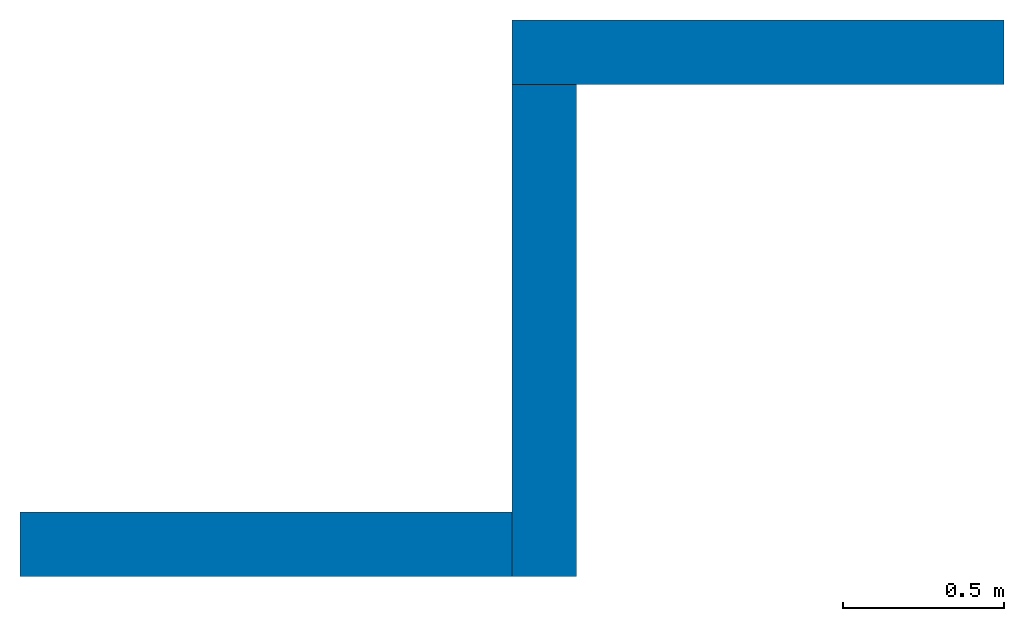
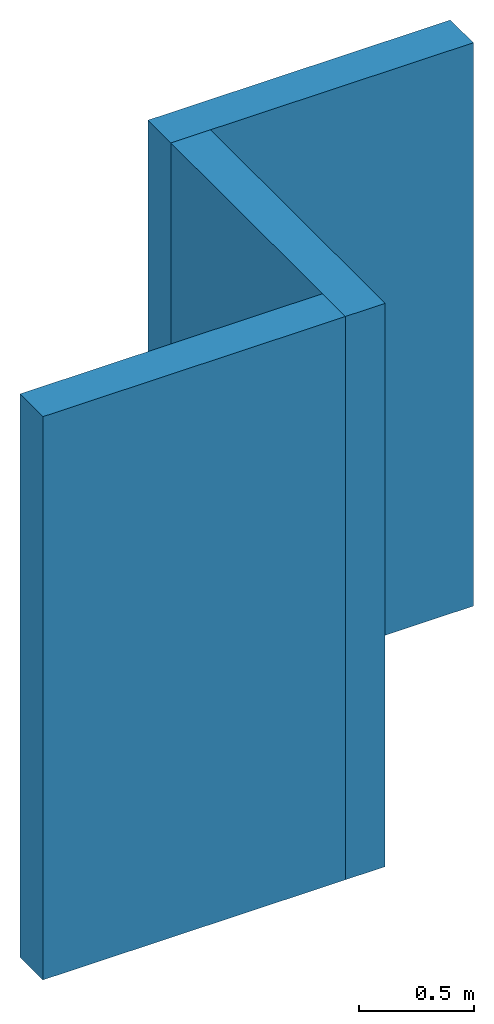
# One storey: 3 walls.
"""IFC2X3 building model written with IfcOpenShell, lengths in feet."""

from ifc_helpers import new_model, entity, si_unit, converted_unit, frame, origin_with_axes, place, context, subcontext, project, spatial, faceted_brep, source, transform, mapped, element, save


model = new_model("IFC2X3")

# Units and contexts
model_context = context("Model", 3, precision=1e-05, world=origin_with_axes())
plan_context = context("Plan", 2, precision=1e-05, world=origin_with_axes())
body_context = subcontext(model_context, "Body", "Model", "MODEL_VIEW")
ifc_project = project(units=[converted_unit("LENGTHUNIT", "foot", entity("IfcReal", 0.3048), si_unit("LENGTHUNIT", "METRE"), dimensions=[1, 0, 0, 0, 0, 0, 0]), converted_unit("AREAUNIT", "square foot", entity("IfcReal", 0.09290304), si_unit("AREAUNIT", "SQUARE_METRE"), dimensions=[2, 0, 0, 0, 0, 0, 0]), converted_unit("VOLUMEUNIT", "cubic foot", entity("IfcReal", 0.0283168467116885), si_unit("VOLUMEUNIT", "CUBIC_METRE"), dimensions=[3, 0, 0, 0, 0, 0, 0])], contexts=[model_context, plan_context])

# Site, building, storey
site_placement = place(None, origin_with_axes())
site = spatial("IfcSite", under=ifc_project, at=site_placement)
building_placement = place(site_placement, origin_with_axes())
building = spatial("IfcBuilding", under=site, at=building_placement, Name="Building")
storey_placement = place(building_placement, origin_with_axes())
storey = spatial("IfcBuildingStorey", under=building, at=storey_placement, Name="Ground Floor")

# Walls
shared_shape_1 = source(origin_with_axes(), body_context, "Body", "Brep", [
    faceted_brep([(0.0, 0.0, 9.84251976013184), (5.0, 0.0, 9.84251976013184), (5.0, 0.0, 0.0), (0.0, 0.0, 0.0), (0.0, -0.656167984008789, 9.84251976013184), (0.0, -0.656167984008789, 0.0), (5.0, -0.656167984008789, 0.0), (5.0, -0.656167984008789, 9.84251976013184)], [[[0, 1, 2, 3]], [[4, 5, 6, 7]], [[3, 2, 6, 5]], [[0, 3, 5, 4]], [[2, 1, 7, 6]], [[1, 0, 4, 7]]]),
])
wall_1_placement = place(storey_placement, frame((5.00000055067808, 4.9999997684649, 0.0), z_axis=(0.0, 0.0, 1.0), x_axis=(1.0, 0.0, 0.0)))
element("IfcWall", 1, at=wall_1_placement, inside=storey, Name="Wall.002", context=body_context, shape_type="MappedRepresentation", body=[
    mapped(shared_shape_1, transform((0.0, 0.0, 0.0), x_axis=(1.0, 0.0, 0.0), y_axis=(0.0, 1.0, 0.0), z_axis=(0.0, 0.0, 1.0), scale=1.0)),
])
shared_shape_2 = source(origin_with_axes(), body_context, "Body", "Brep", [
    faceted_brep([(0.0, 0.0, 9.84251976013184), (5.0, 0.0, 9.84251976013184), (5.0, 0.0, 0.0), (0.0, 0.0, 0.0), (0.0, -0.656167984008789, 9.84251976013184), (0.0, -0.656167984008789, 0.0), (5.0, -0.656167984008789, 0.0), (5.0, -0.656167984008789, 9.84251976013184)], [[[0, 1, 2, 3]], [[4, 5, 6, 7]], [[3, 2, 6, 5]], [[0, 3, 5, 4]], [[2, 1, 7, 6]], [[1, 0, 4, 7]]]),
])
wall_2_placement = place(storey_placement, frame((4.9999997684649, -0.656167988780289, 0.0), z_axis=(0.0, 0.0, 1.0), x_axis=(1.94707183709397e-07, 1.0, 0.0)))
element("IfcWall", 2, at=wall_2_placement, inside=storey, Name="Wall.001", context=body_context, shape_type="MappedRepresentation", body=[
    mapped(shared_shape_2, transform((0.0, 0.0, 0.0), x_axis=(1.0, 0.0, 0.0), y_axis=(0.0, 1.0, 0.0), z_axis=(0.0, 0.0, 1.0), scale=1.0)),
])
shared_shape_3 = source(origin_with_axes(), body_context, "Body", "Brep", [
    faceted_brep([(0.0, 0.0, 9.84251976013184), (5.0, 0.0, 9.84251976013184), (5.0, 0.0, 0.0), (0.0, 0.0, 0.0), (0.0, -0.656167984008789, 9.84251976013184), (0.0, -0.656167984008789, 0.0), (5.0, -0.656167984008789, 0.0), (5.0, -0.656167984008789, 9.84251976013184)], [[[0, 1, 2, 3]], [[4, 5, 6, 7]], [[3, 2, 6, 5]], [[0, 3, 5, 4]], [[2, 1, 7, 6]], [[1, 0, 4, 7]]]),
])
wall_3_placement = place(storey_placement, origin_with_axes())
element("IfcWall", 3, at=wall_3_placement, inside=storey, Name="Wall", context=body_context, shape_type="MappedRepresentation", body=[
    mapped(shared_shape_3, transform((0.0, 0.0, 0.0), x_axis=(1.0, 0.0, 0.0), y_axis=(0.0, 1.0, 0.0), z_axis=(0.0, 0.0, 1.0), scale=1.0)),
])

save(model, "model.ifc")
